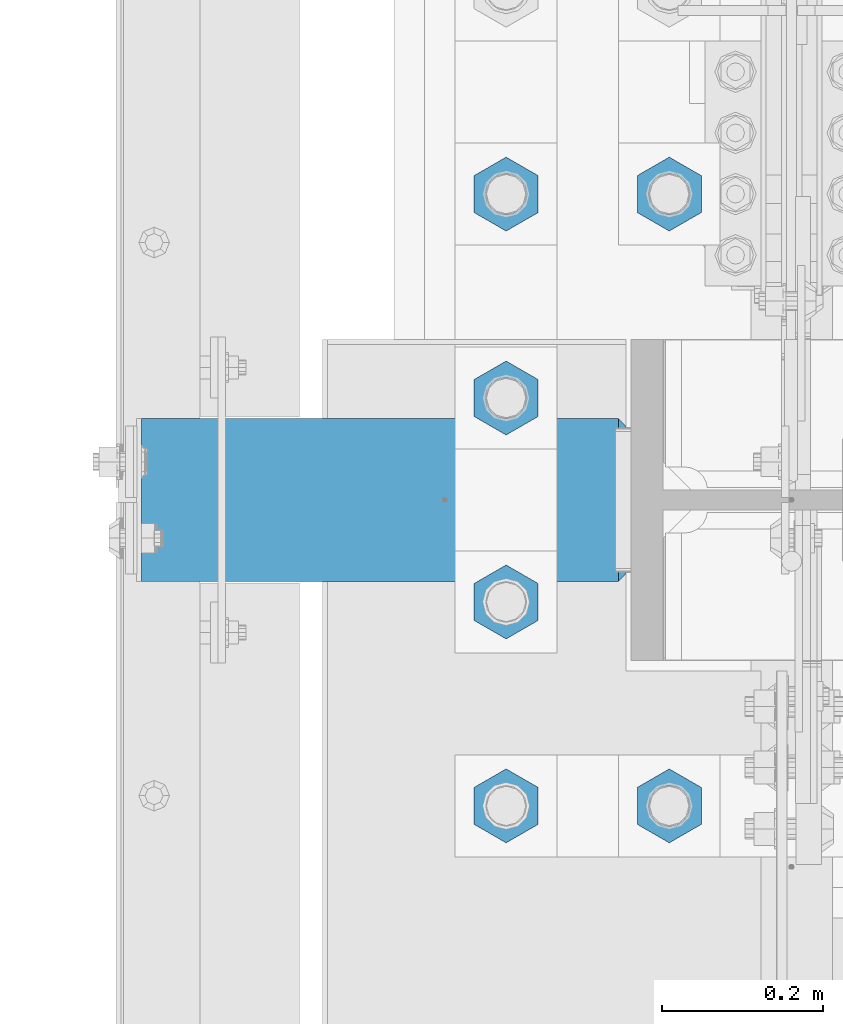
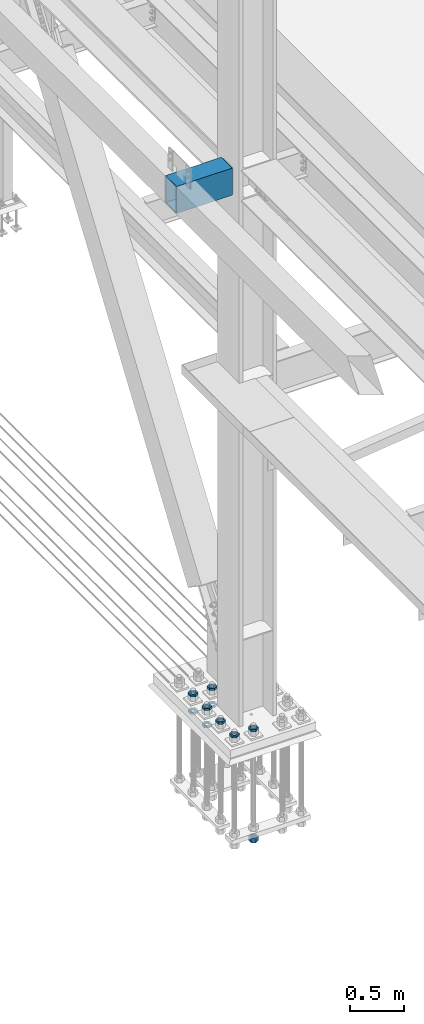
# One storey, part 2365 of 3843: 11 beams, 2 elements without a shape of their own.
"""IFC2X3 building model written with IfcOpenShell, lengths in millimetres."""

from ifc_helpers import new_model, si_unit, frame, origin_with_axes, place, context, subcontext, project, spatial, faceted_brep, material, type_object, element, aggregate, save


model = new_model("IFC2X3")

# Units and contexts
model_context = context("Model", 3, precision=1e-05, world=origin_with_axes())
body_context = subcontext(model_context, "Body", "Model", "MODEL_VIEW")
ifc_project = project(units=[si_unit("LENGTHUNIT", "METRE", prefix="MILLI"), si_unit("AREAUNIT", "SQUARE_METRE"), si_unit("VOLUMEUNIT", "CUBIC_METRE"), si_unit("MASSUNIT", "GRAM", prefix="KILO"), si_unit("TIMEUNIT", "SECOND"), si_unit("PLANEANGLEUNIT", "RADIAN"), si_unit("SOLIDANGLEUNIT", "STERADIAN"), si_unit("THERMODYNAMICTEMPERATUREUNIT", "DEGREE_CELSIUS"), si_unit("LUMINOUSINTENSITYUNIT", "LUMEN")], contexts=[model_context])

# Site, building, storey
site_placement = place(None, origin_with_axes())
site = spatial("IfcSite", under=ifc_project, at=site_placement, CompositionType="ELEMENT")
building_placement = place(site_placement, origin_with_axes())
building = spatial("IfcBuilding", under=site, at=building_placement, Name="Undefined", CompositionType="ELEMENT")
storey_placement = place(building_placement, origin_with_axes())
storey = spatial("IfcBuildingStorey", under=building, at=storey_placement, Name="Undefined", CompositionType="ELEMENT", Elevation=0.0)

# Assembly, beams
assembly_1_placement = place(storey_placement, origin_with_axes())
assembly_1 = element("IfcElementAssembly", 1, at=assembly_1_placement, inside=storey, Name="TEMPLATE", AssemblyPlace="NOTDEFINED", PredefinedType="RIGID_FRAME")
ifc_material_1 = material(Name="STEEL/A572-50")
beam_type_1 = type_object("IfcBeamType", Name="2_HALF_NUT", PredefinedType="NOTDEFINED")
beam_1_placement = place(assembly_1_placement, frame((36220.4, 67398.9, 30060.9), z_axis=(-1.0, 0.0, 0.0), x_axis=(0.0, 0.0, -1.0)))
beam_1 = element("IfcBeam", 2, at=beam_1_placement, type_object=beam_type_1, material=ifc_material_1, Name="NUT", ObjectType="2_HALF_NUT", context=body_context, shape_type="Brep", body=[
    faceted_brep([(0.0, -46.0369987487793, 0.0), (0.0, -23.0184993743896, -39.869213104248), (25.4000000000015, -23.0184993743896, -39.869213104248), (25.4000000000015, -46.0369987487793, 0.0), (0.0, 23.0184993743896, -39.869213104248), (25.4000000000015, 23.0184993743896, -39.869213104248), (0.0, 46.0369987487793, 0.0), (25.4000000000015, 46.0369987487793, 0.0), (0.0, 23.0184993743896, 39.869213104248), (25.4000000000015, 23.0184993743896, 39.869213104248), (0.0, -23.0184993743896, 39.869213104248), (25.4000000000015, -23.0184993743896, 39.869213104248), (0.0, 0.0, 26.1940002441406), (0.0, 11.3650617044477, 23.5999013092805), (25.4000000000015, 11.3650617044477, 23.5999013092805), (25.4000000000015, 0.0, 26.1940002441406), (0.0, 20.4791109456419, 16.3316083006721), (25.4000000000015, 20.4791109456419, 16.3316083006721), (0.0, 25.5370200498292, 5.82867859874386), (25.4000000000015, 25.5370200498292, 5.82867859874386), (0.0, 25.5370200498292, -5.82867859874386), (25.4000000000015, 25.5370200498292, -5.82867859874386), (0.0, 20.4791109456419, -16.3316083006721), (25.4000000000015, 20.4791109456419, -16.3316083006721), (0.0, 11.3650617044477, -23.5999013092805), (25.4000000000015, 11.3650617044477, -23.5999013092805), (0.0, 0.0, -26.1940002441406), (25.4000000000015, 0.0, -26.1940002441406), (0.0, -11.3650617044477, -23.5999013092805), (25.4000000000015, -11.3650617044477, -23.5999013092805), (0.0, -20.4791109456419, -16.3316083006721), (25.4000000000015, -20.4791109456419, -16.3316083006721), (0.0, -25.5370200498292, -5.82867859874386), (25.4000000000015, -25.5370200498292, -5.82867859874386), (0.0, -25.5370200498292, 5.82867859874386), (25.4000000000015, -25.5370200498292, 5.82867859874386), (0.0, -20.4791109456419, 16.3316083006721), (25.4000000000015, -20.4791109456419, 16.3316083006721), (0.0, -11.3650617044477, 23.5999013092805), (25.4000000000015, -11.3650617044477, 23.5999013092805)], [[[0, 1, 2, 3]], [[1, 4, 5, 2]], [[4, 6, 7, 5]], [[6, 8, 9, 7]], [[8, 10, 11, 9]], [[10, 0, 3, 11]], [[12, 13, 14, 15]], [[13, 16, 17, 14]], [[16, 18, 19, 17]], [[18, 20, 21, 19]], [[20, 22, 23, 21]], [[22, 24, 25, 23]], [[24, 26, 27, 25]], [[26, 28, 29, 27]], [[28, 30, 31, 29]], [[30, 32, 33, 31]], [[32, 34, 35, 33]], [[34, 36, 37, 35]], [[36, 38, 39, 37]], [[38, 12, 15, 39]], [[5, 7, 9, 11, 3, 2], [17, 19, 21, 23, 25, 27, 29, 31, 33, 35, 37, 39, 15, 14]], [[10, 8, 6, 4, 1, 0], [38, 36, 34, 32, 30, 28, 26, 24, 22, 20, 18, 16, 13, 12]]]),
])
beam_2_placement = place(assembly_1_placement, frame((36423.6, 67652.9, 30060.9), z_axis=(1.0, 0.0, 0.0), x_axis=(0.0, 0.0, -1.0)))
beam_2 = element("IfcBeam", 3, at=beam_2_placement, type_object=beam_type_1, material=ifc_material_1, Name="NUT", ObjectType="2_HALF_NUT", context=body_context, shape_type="Brep", body=[
    faceted_brep([(0.0, -46.0369987487793, 0.0), (0.0, -23.0184993743896, -39.869213104248), (25.4000000000015, -23.0184993743896, -39.869213104248), (25.4000000000015, -46.0369987487793, 0.0), (0.0, 23.0184993743896, -39.869213104248), (25.4000000000015, 23.0184993743896, -39.869213104248), (0.0, 46.0369987487793, 0.0), (25.4000000000015, 46.0369987487793, 0.0), (0.0, 23.0184993743896, 39.869213104248), (25.4000000000015, 23.0184993743896, 39.869213104248), (0.0, -23.0184993743896, 39.869213104248), (25.4000000000015, -23.0184993743896, 39.869213104248), (0.0, 0.0, 26.1940002441406), (0.0, 11.3650617044477, 23.5999013092805), (25.4000000000015, 11.3650617044477, 23.5999013092805), (25.4000000000015, 0.0, 26.1940002441406), (0.0, 20.4791109456419, 16.3316083006721), (25.4000000000015, 20.4791109456419, 16.3316083006721), (0.0, 25.5370200498292, 5.82867859874386), (25.4000000000015, 25.5370200498292, 5.82867859874386), (0.0, 25.5370200498292, -5.82867859874386), (25.4000000000015, 25.5370200498292, -5.82867859874386), (0.0, 20.4791109456419, -16.3316083006721), (25.4000000000015, 20.4791109456419, -16.3316083006721), (0.0, 11.3650617044477, -23.5999013092805), (25.4000000000015, 11.3650617044477, -23.5999013092805), (0.0, 0.0, -26.1940002441406), (25.4000000000015, 0.0, -26.1940002441406), (0.0, -11.3650617044477, -23.5999013092805), (25.4000000000015, -11.3650617044477, -23.5999013092805), (0.0, -20.4791109456419, -16.3316083006721), (25.4000000000015, -20.4791109456419, -16.3316083006721), (0.0, -25.5370200498292, -5.82867859874386), (25.4000000000015, -25.5370200498292, -5.82867859874386), (0.0, -25.5370200498292, 5.82867859874386), (25.4000000000015, -25.5370200498292, 5.82867859874386), (0.0, -20.4791109456419, 16.3316083006721), (25.4000000000015, -20.4791109456419, 16.3316083006721), (0.0, -11.3650617044477, 23.5999013092805), (25.4000000000015, -11.3650617044477, 23.5999013092805)], [[[0, 1, 2, 3]], [[1, 4, 5, 2]], [[4, 6, 7, 5]], [[6, 8, 9, 7]], [[8, 10, 11, 9]], [[10, 0, 3, 11]], [[12, 13, 14, 15]], [[13, 16, 17, 14]], [[16, 18, 19, 17]], [[18, 20, 21, 19]], [[20, 22, 23, 21]], [[22, 24, 25, 23]], [[24, 26, 27, 25]], [[26, 28, 29, 27]], [[28, 30, 31, 29]], [[30, 32, 33, 31]], [[32, 34, 35, 33]], [[34, 36, 37, 35]], [[36, 38, 39, 37]], [[38, 12, 15, 39]], [[5, 7, 9, 11, 3, 2], [17, 19, 21, 23, 25, 27, 29, 31, 33, 35, 37, 39, 15, 14]], [[10, 8, 6, 4, 1, 0], [38, 36, 34, 32, 30, 28, 26, 24, 22, 20, 18, 16, 13, 12]]]),
])
beam_3_placement = place(assembly_1_placement, frame((36220.4, 67652.9, 30060.9), z_axis=(1.0, 0.0, 0.0), x_axis=(0.0, 0.0, -1.0)))
beam_3 = element("IfcBeam", 4, at=beam_3_placement, type_object=beam_type_1, material=ifc_material_1, Name="NUT", ObjectType="2_HALF_NUT", context=body_context, shape_type="Brep", body=[
    faceted_brep([(0.0, -46.0369987487793, 0.0), (0.0, -23.0184993743896, -39.869213104248), (25.4000000000015, -23.0184993743896, -39.869213104248), (25.4000000000015, -46.0369987487793, 0.0), (0.0, 23.0184993743896, -39.869213104248), (25.4000000000015, 23.0184993743896, -39.869213104248), (0.0, 46.0369987487793, 0.0), (25.4000000000015, 46.0369987487793, 0.0), (0.0, 23.0184993743896, 39.869213104248), (25.4000000000015, 23.0184993743896, 39.869213104248), (0.0, -23.0184993743896, 39.869213104248), (25.4000000000015, -23.0184993743896, 39.869213104248), (0.0, 0.0, 26.1940002441406), (0.0, 11.3650617044477, 23.5999013092805), (25.4000000000015, 11.3650617044477, 23.5999013092805), (25.4000000000015, 0.0, 26.1940002441406), (0.0, 20.4791109456419, 16.3316083006721), (25.4000000000015, 20.4791109456419, 16.3316083006721), (0.0, 25.5370200498292, 5.82867859874386), (25.4000000000015, 25.5370200498292, 5.82867859874386), (0.0, 25.5370200498292, -5.82867859874386), (25.4000000000015, 25.5370200498292, -5.82867859874386), (0.0, 20.4791109456419, -16.3316083006721), (25.4000000000015, 20.4791109456419, -16.3316083006721), (0.0, 11.3650617044477, -23.5999013092805), (25.4000000000015, 11.3650617044477, -23.5999013092805), (0.0, 0.0, -26.1940002441406), (25.4000000000015, 0.0, -26.1940002441406), (0.0, -11.3650617044477, -23.5999013092805), (25.4000000000015, -11.3650617044477, -23.5999013092805), (0.0, -20.4791109456419, -16.3316083006721), (25.4000000000015, -20.4791109456419, -16.3316083006721), (0.0, -25.5370200498292, -5.82867859874386), (25.4000000000015, -25.5370200498292, -5.82867859874386), (0.0, -25.5370200498292, 5.82867859874386), (25.4000000000015, -25.5370200498292, 5.82867859874386), (0.0, -20.4791109456419, 16.3316083006721), (25.4000000000015, -20.4791109456419, 16.3316083006721), (0.0, -11.3650617044477, 23.5999013092805), (25.4000000000015, -11.3650617044477, 23.5999013092805)], [[[0, 1, 2, 3]], [[1, 4, 5, 2]], [[4, 6, 7, 5]], [[6, 8, 9, 7]], [[8, 10, 11, 9]], [[10, 0, 3, 11]], [[12, 13, 14, 15]], [[13, 16, 17, 14]], [[16, 18, 19, 17]], [[18, 20, 21, 19]], [[20, 22, 23, 21]], [[22, 24, 25, 23]], [[24, 26, 27, 25]], [[26, 28, 29, 27]], [[28, 30, 31, 29]], [[30, 32, 33, 31]], [[32, 34, 35, 33]], [[34, 36, 37, 35]], [[36, 38, 39, 37]], [[38, 12, 15, 39]], [[5, 7, 9, 11, 3, 2], [17, 19, 21, 23, 25, 27, 29, 31, 33, 35, 37, 39, 15, 14]], [[10, 8, 6, 4, 1, 0], [38, 36, 34, 32, 30, 28, 26, 24, 22, 20, 18, 16, 13, 12]]]),
])
beam_4_placement = place(assembly_1_placement, frame((36423.6, 67652.9, 30257.75), z_axis=(-1.0, 0.0, 0.0), x_axis=(0.0, 0.0, -1.0)))
beam_4 = element("IfcBeam", 5, at=beam_4_placement, type_object=beam_type_1, material=ifc_material_1, Name="NUT", ObjectType="2_HALF_NUT", context=body_context, shape_type="Brep", body=[
    faceted_brep([(0.0, -46.0369987487793, 0.0), (0.0, -23.0184993743896, -39.869213104248), (25.4000000000015, -23.0184993743896, -39.869213104248), (25.4000000000015, -46.0369987487793, 0.0), (0.0, 23.0184993743896, -39.869213104248), (25.4000000000015, 23.0184993743896, -39.869213104248), (0.0, 46.0369987487793, 0.0), (25.4000000000015, 46.0369987487793, 0.0), (0.0, 23.0184993743896, 39.869213104248), (25.4000000000015, 23.0184993743896, 39.869213104248), (0.0, -23.0184993743896, 39.869213104248), (25.4000000000015, -23.0184993743896, 39.869213104248), (0.0, 0.0, 26.1940002441406), (0.0, 11.3650617044477, 23.5999013092805), (25.4000000000015, 11.3650617044477, 23.5999013092805), (25.4000000000015, 0.0, 26.1940002441406), (0.0, 20.4791109456419, 16.3316083006721), (25.4000000000015, 20.4791109456419, 16.3316083006721), (0.0, 25.5370200498292, 5.82867859874386), (25.4000000000015, 25.5370200498292, 5.82867859874386), (0.0, 25.5370200498292, -5.82867859874386), (25.4000000000015, 25.5370200498292, -5.82867859874386), (0.0, 20.4791109456419, -16.3316083006721), (25.4000000000015, 20.4791109456419, -16.3316083006721), (0.0, 11.3650617044477, -23.5999013092805), (25.4000000000015, 11.3650617044477, -23.5999013092805), (0.0, 0.0, -26.1940002441406), (25.4000000000015, 0.0, -26.1940002441406), (0.0, -11.3650617044477, -23.5999013092805), (25.4000000000015, -11.3650617044477, -23.5999013092805), (0.0, -20.4791109456419, -16.3316083006721), (25.4000000000015, -20.4791109456419, -16.3316083006721), (0.0, -25.5370200498292, -5.82867859874386), (25.4000000000015, -25.5370200498292, -5.82867859874386), (0.0, -25.5370200498292, 5.82867859874386), (25.4000000000015, -25.5370200498292, 5.82867859874386), (0.0, -20.4791109456419, 16.3316083006721), (25.4000000000015, -20.4791109456419, 16.3316083006721), (0.0, -11.3650617044477, 23.5999013092805), (25.4000000000015, -11.3650617044477, 23.5999013092805)], [[[0, 1, 2, 3]], [[1, 4, 5, 2]], [[4, 6, 7, 5]], [[6, 8, 9, 7]], [[8, 10, 11, 9]], [[10, 0, 3, 11]], [[12, 13, 14, 15]], [[13, 16, 17, 14]], [[16, 18, 19, 17]], [[18, 20, 21, 19]], [[20, 22, 23, 21]], [[22, 24, 25, 23]], [[24, 26, 27, 25]], [[26, 28, 29, 27]], [[28, 30, 31, 29]], [[30, 32, 33, 31]], [[32, 34, 35, 33]], [[34, 36, 37, 35]], [[36, 38, 39, 37]], [[38, 12, 15, 39]], [[5, 7, 9, 11, 3, 2], [17, 19, 21, 23, 25, 27, 29, 31, 33, 35, 37, 39, 15, 14]], [[10, 8, 6, 4, 1, 0], [38, 36, 34, 32, 30, 28, 26, 24, 22, 20, 18, 16, 13, 12]]]),
])
beam_5_placement = place(assembly_1_placement, frame((36220.4, 67652.9, 30257.75), z_axis=(-1.0, 0.0, 0.0), x_axis=(0.0, 0.0, -1.0)))
beam_5 = element("IfcBeam", 6, at=beam_5_placement, type_object=beam_type_1, material=ifc_material_1, Name="NUT", ObjectType="2_HALF_NUT", context=body_context, shape_type="Brep", body=[
    faceted_brep([(0.0, -46.0369987487793, 0.0), (0.0, -23.0184993743896, -39.869213104248), (25.4000000000015, -23.0184993743896, -39.869213104248), (25.4000000000015, -46.0369987487793, 0.0), (0.0, 23.0184993743896, -39.869213104248), (25.4000000000015, 23.0184993743896, -39.869213104248), (0.0, 46.0369987487793, 0.0), (25.4000000000015, 46.0369987487793, 0.0), (0.0, 23.0184993743896, 39.869213104248), (25.4000000000015, 23.0184993743896, 39.869213104248), (0.0, -23.0184993743896, 39.869213104248), (25.4000000000015, -23.0184993743896, 39.869213104248), (0.0, 0.0, 26.1940002441406), (0.0, 11.3650617044477, 23.5999013092805), (25.4000000000015, 11.3650617044477, 23.5999013092805), (25.4000000000015, 0.0, 26.1940002441406), (0.0, 20.4791109456419, 16.3316083006721), (25.4000000000015, 20.4791109456419, 16.3316083006721), (0.0, 25.5370200498292, 5.82867859874386), (25.4000000000015, 25.5370200498292, 5.82867859874386), (0.0, 25.5370200498292, -5.82867859874386), (25.4000000000015, 25.5370200498292, -5.82867859874386), (0.0, 20.4791109456419, -16.3316083006721), (25.4000000000015, 20.4791109456419, -16.3316083006721), (0.0, 11.3650617044477, -23.5999013092805), (25.4000000000015, 11.3650617044477, -23.5999013092805), (0.0, 0.0, -26.1940002441406), (25.4000000000015, 0.0, -26.1940002441406), (0.0, -11.3650617044477, -23.5999013092805), (25.4000000000015, -11.3650617044477, -23.5999013092805), (0.0, -20.4791109456419, -16.3316083006721), (25.4000000000015, -20.4791109456419, -16.3316083006721), (0.0, -25.5370200498292, -5.82867859874386), (25.4000000000015, -25.5370200498292, -5.82867859874386), (0.0, -25.5370200498292, 5.82867859874386), (25.4000000000015, -25.5370200498292, 5.82867859874386), (0.0, -20.4791109456419, 16.3316083006721), (25.4000000000015, -20.4791109456419, 16.3316083006721), (0.0, -11.3650617044477, 23.5999013092805), (25.4000000000015, -11.3650617044477, 23.5999013092805)], [[[0, 1, 2, 3]], [[1, 4, 5, 2]], [[4, 6, 7, 5]], [[6, 8, 9, 7]], [[8, 10, 11, 9]], [[10, 0, 3, 11]], [[12, 13, 14, 15]], [[13, 16, 17, 14]], [[16, 18, 19, 17]], [[18, 20, 21, 19]], [[20, 22, 23, 21]], [[22, 24, 25, 23]], [[24, 26, 27, 25]], [[26, 28, 29, 27]], [[28, 30, 31, 29]], [[30, 32, 33, 31]], [[32, 34, 35, 33]], [[34, 36, 37, 35]], [[36, 38, 39, 37]], [[38, 12, 15, 39]], [[5, 7, 9, 11, 3, 2], [17, 19, 21, 23, 25, 27, 29, 31, 33, 35, 37, 39, 15, 14]], [[10, 8, 6, 4, 1, 0], [38, 36, 34, 32, 30, 28, 26, 24, 22, 20, 18, 16, 13, 12]]]),
])
beam_6_placement = place(assembly_1_placement, frame((36220.4, 67398.9, 30257.75), z_axis=(1.0, 0.0, 0.0), x_axis=(0.0, 0.0, -1.0)))
beam_6 = element("IfcBeam", 7, at=beam_6_placement, type_object=beam_type_1, material=ifc_material_1, Name="NUT", ObjectType="2_HALF_NUT", context=body_context, shape_type="Brep", body=[
    faceted_brep([(0.0, -46.0369987487793, 0.0), (0.0, -23.0184993743896, -39.869213104248), (25.4000000000015, -23.0184993743896, -39.869213104248), (25.4000000000015, -46.0369987487793, 0.0), (0.0, 23.0184993743896, -39.869213104248), (25.4000000000015, 23.0184993743896, -39.869213104248), (0.0, 46.0369987487793, 0.0), (25.4000000000015, 46.0369987487793, 0.0), (0.0, 23.0184993743896, 39.869213104248), (25.4000000000015, 23.0184993743896, 39.869213104248), (0.0, -23.0184993743896, 39.869213104248), (25.4000000000015, -23.0184993743896, 39.869213104248), (0.0, 0.0, 26.1940002441406), (0.0, 11.3650617044477, 23.5999013092805), (25.4000000000015, 11.3650617044477, 23.5999013092805), (25.4000000000015, 0.0, 26.1940002441406), (0.0, 20.4791109456419, 16.3316083006721), (25.4000000000015, 20.4791109456419, 16.3316083006721), (0.0, 25.5370200498292, 5.82867859874386), (25.4000000000015, 25.5370200498292, 5.82867859874386), (0.0, 25.5370200498292, -5.82867859874386), (25.4000000000015, 25.5370200498292, -5.82867859874386), (0.0, 20.4791109456419, -16.3316083006721), (25.4000000000015, 20.4791109456419, -16.3316083006721), (0.0, 11.3650617044477, -23.5999013092805), (25.4000000000015, 11.3650617044477, -23.5999013092805), (0.0, 0.0, -26.1940002441406), (25.4000000000015, 0.0, -26.1940002441406), (0.0, -11.3650617044477, -23.5999013092805), (25.4000000000015, -11.3650617044477, -23.5999013092805), (0.0, -20.4791109456419, -16.3316083006721), (25.4000000000015, -20.4791109456419, -16.3316083006721), (0.0, -25.5370200498292, -5.82867859874386), (25.4000000000015, -25.5370200498292, -5.82867859874386), (0.0, -25.5370200498292, 5.82867859874386), (25.4000000000015, -25.5370200498292, 5.82867859874386), (0.0, -20.4791109456419, 16.3316083006721), (25.4000000000015, -20.4791109456419, 16.3316083006721), (0.0, -11.3650617044477, 23.5999013092805), (25.4000000000015, -11.3650617044477, 23.5999013092805)], [[[0, 1, 2, 3]], [[1, 4, 5, 2]], [[4, 6, 7, 5]], [[6, 8, 9, 7]], [[8, 10, 11, 9]], [[10, 0, 3, 11]], [[12, 13, 14, 15]], [[13, 16, 17, 14]], [[16, 18, 19, 17]], [[18, 20, 21, 19]], [[20, 22, 23, 21]], [[22, 24, 25, 23]], [[24, 26, 27, 25]], [[26, 28, 29, 27]], [[28, 30, 31, 29]], [[30, 32, 33, 31]], [[32, 34, 35, 33]], [[34, 36, 37, 35]], [[36, 38, 39, 37]], [[38, 12, 15, 39]], [[5, 7, 9, 11, 3, 2], [17, 19, 21, 23, 25, 27, 29, 31, 33, 35, 37, 39, 15, 14]], [[10, 8, 6, 4, 1, 0], [38, 36, 34, 32, 30, 28, 26, 24, 22, 20, 18, 16, 13, 12]]]),
])
beam_7_placement = place(assembly_1_placement, frame((36220.4, 67144.9, 30257.75), z_axis=(1.0, 0.0, 0.0), x_axis=(0.0, 0.0, -1.0)))
beam_7 = element("IfcBeam", 8, at=beam_7_placement, type_object=beam_type_1, material=ifc_material_1, Name="NUT", ObjectType="2_HALF_NUT", context=body_context, shape_type="Brep", body=[
    faceted_brep([(0.0, -46.0369987487793, 0.0), (0.0, -23.0184993743896, -39.869213104248), (25.4000000000015, -23.0184993743896, -39.869213104248), (25.4000000000015, -46.0369987487793, 0.0), (0.0, 23.0184993743896, -39.869213104248), (25.4000000000015, 23.0184993743896, -39.869213104248), (0.0, 46.0369987487793, 0.0), (25.4000000000015, 46.0369987487793, 0.0), (0.0, 23.0184993743896, 39.869213104248), (25.4000000000015, 23.0184993743896, 39.869213104248), (0.0, -23.0184993743896, 39.869213104248), (25.4000000000015, -23.0184993743896, 39.869213104248), (0.0, 0.0, 26.1940002441406), (0.0, 11.3650617044477, 23.5999013092805), (25.4000000000015, 11.3650617044477, 23.5999013092805), (25.4000000000015, 0.0, 26.1940002441406), (0.0, 20.4791109456419, 16.3316083006721), (25.4000000000015, 20.4791109456419, 16.3316083006721), (0.0, 25.5370200498292, 5.82867859874386), (25.4000000000015, 25.5370200498292, 5.82867859874386), (0.0, 25.5370200498292, -5.82867859874386), (25.4000000000015, 25.5370200498292, -5.82867859874386), (0.0, 20.4791109456419, -16.3316083006721), (25.4000000000015, 20.4791109456419, -16.3316083006721), (0.0, 11.3650617044477, -23.5999013092805), (25.4000000000015, 11.3650617044477, -23.5999013092805), (0.0, 0.0, -26.1940002441406), (25.4000000000015, 0.0, -26.1940002441406), (0.0, -11.3650617044477, -23.5999013092805), (25.4000000000015, -11.3650617044477, -23.5999013092805), (0.0, -20.4791109456419, -16.3316083006721), (25.4000000000015, -20.4791109456419, -16.3316083006721), (0.0, -25.5370200498292, -5.82867859874386), (25.4000000000015, -25.5370200498292, -5.82867859874386), (0.0, -25.5370200498292, 5.82867859874386), (25.4000000000015, -25.5370200498292, 5.82867859874386), (0.0, -20.4791109456419, 16.3316083006721), (25.4000000000015, -20.4791109456419, 16.3316083006721), (0.0, -11.3650617044477, 23.5999013092805), (25.4000000000015, -11.3650617044477, 23.5999013092805)], [[[0, 1, 2, 3]], [[1, 4, 5, 2]], [[4, 6, 7, 5]], [[6, 8, 9, 7]], [[8, 10, 11, 9]], [[10, 0, 3, 11]], [[12, 13, 14, 15]], [[13, 16, 17, 14]], [[16, 18, 19, 17]], [[18, 20, 21, 19]], [[20, 22, 23, 21]], [[22, 24, 25, 23]], [[24, 26, 27, 25]], [[26, 28, 29, 27]], [[28, 30, 31, 29]], [[30, 32, 33, 31]], [[32, 34, 35, 33]], [[34, 36, 37, 35]], [[36, 38, 39, 37]], [[38, 12, 15, 39]], [[5, 7, 9, 11, 3, 2], [17, 19, 21, 23, 25, 27, 29, 31, 33, 35, 37, 39, 15, 14]], [[10, 8, 6, 4, 1, 0], [38, 36, 34, 32, 30, 28, 26, 24, 22, 20, 18, 16, 13, 12]]]),
])
beam_8_placement = place(assembly_1_placement, frame((36220.4, 66890.9, 30257.75), z_axis=(1.0, 0.0, 0.0), x_axis=(0.0, 0.0, -1.0)))
beam_8 = element("IfcBeam", 9, at=beam_8_placement, type_object=beam_type_1, material=ifc_material_1, Name="NUT", ObjectType="2_HALF_NUT", context=body_context, shape_type="Brep", body=[
    faceted_brep([(0.0, -46.0369987487793, 0.0), (0.0, -23.0184993743896, -39.869213104248), (25.4000000000015, -23.0184993743896, -39.869213104248), (25.4000000000015, -46.0369987487793, 0.0), (0.0, 23.0184993743896, -39.869213104248), (25.4000000000015, 23.0184993743896, -39.869213104248), (0.0, 46.0369987487793, 0.0), (25.4000000000015, 46.0369987487793, 0.0), (0.0, 23.0184993743896, 39.869213104248), (25.4000000000015, 23.0184993743896, 39.869213104248), (0.0, -23.0184993743896, 39.869213104248), (25.4000000000015, -23.0184993743896, 39.869213104248), (0.0, 0.0, 26.1940002441406), (0.0, 11.3650617044477, 23.5999013092805), (25.4000000000015, 11.3650617044477, 23.5999013092805), (25.4000000000015, 0.0, 26.1940002441406), (0.0, 20.4791109456419, 16.3316083006721), (25.4000000000015, 20.4791109456419, 16.3316083006721), (0.0, 25.5370200498292, 5.82867859874386), (25.4000000000015, 25.5370200498292, 5.82867859874386), (0.0, 25.5370200498292, -5.82867859874386), (25.4000000000015, 25.5370200498292, -5.82867859874386), (0.0, 20.4791109456419, -16.3316083006721), (25.4000000000015, 20.4791109456419, -16.3316083006721), (0.0, 11.3650617044477, -23.5999013092805), (25.4000000000015, 11.3650617044477, -23.5999013092805), (0.0, 0.0, -26.1940002441406), (25.4000000000015, 0.0, -26.1940002441406), (0.0, -11.3650617044477, -23.5999013092805), (25.4000000000015, -11.3650617044477, -23.5999013092805), (0.0, -20.4791109456419, -16.3316083006721), (25.4000000000015, -20.4791109456419, -16.3316083006721), (0.0, -25.5370200498292, -5.82867859874386), (25.4000000000015, -25.5370200498292, -5.82867859874386), (0.0, -25.5370200498292, 5.82867859874386), (25.4000000000015, -25.5370200498292, 5.82867859874386), (0.0, -20.4791109456419, 16.3316083006721), (25.4000000000015, -20.4791109456419, 16.3316083006721), (0.0, -11.3650617044477, 23.5999013092805), (25.4000000000015, -11.3650617044477, 23.5999013092805)], [[[0, 1, 2, 3]], [[1, 4, 5, 2]], [[4, 6, 7, 5]], [[6, 8, 9, 7]], [[8, 10, 11, 9]], [[10, 0, 3, 11]], [[12, 13, 14, 15]], [[13, 16, 17, 14]], [[16, 18, 19, 17]], [[18, 20, 21, 19]], [[20, 22, 23, 21]], [[22, 24, 25, 23]], [[24, 26, 27, 25]], [[26, 28, 29, 27]], [[28, 30, 31, 29]], [[30, 32, 33, 31]], [[32, 34, 35, 33]], [[34, 36, 37, 35]], [[36, 38, 39, 37]], [[38, 12, 15, 39]], [[5, 7, 9, 11, 3, 2], [17, 19, 21, 23, 25, 27, 29, 31, 33, 35, 37, 39, 15, 14]], [[10, 8, 6, 4, 1, 0], [38, 36, 34, 32, 30, 28, 26, 24, 22, 20, 18, 16, 13, 12]]]),
])
beam_9_placement = place(assembly_1_placement, frame((36423.6, 66890.9, 30257.75), z_axis=(1.0, 0.0, 0.0), x_axis=(0.0, 0.0, -1.0)))
beam_9 = element("IfcBeam", 10, at=beam_9_placement, type_object=beam_type_1, material=ifc_material_1, Name="NUT", ObjectType="2_HALF_NUT", context=body_context, shape_type="Brep", body=[
    faceted_brep([(0.0, -46.0369987487793, 0.0), (0.0, -23.0184993743896, -39.869213104248), (25.4000000000015, -23.0184993743896, -39.869213104248), (25.4000000000015, -46.0369987487793, 0.0), (0.0, 23.0184993743896, -39.869213104248), (25.4000000000015, 23.0184993743896, -39.869213104248), (0.0, 46.0369987487793, 0.0), (25.4000000000015, 46.0369987487793, 0.0), (0.0, 23.0184993743896, 39.869213104248), (25.4000000000015, 23.0184993743896, 39.869213104248), (0.0, -23.0184993743896, 39.869213104248), (25.4000000000015, -23.0184993743896, 39.869213104248), (0.0, 0.0, 26.1940002441406), (0.0, 11.3650617044477, 23.5999013092805), (25.4000000000015, 11.3650617044477, 23.5999013092805), (25.4000000000015, 0.0, 26.1940002441406), (0.0, 20.4791109456419, 16.3316083006721), (25.4000000000015, 20.4791109456419, 16.3316083006721), (0.0, 25.5370200498292, 5.82867859874386), (25.4000000000015, 25.5370200498292, 5.82867859874386), (0.0, 25.5370200498292, -5.82867859874386), (25.4000000000015, 25.5370200498292, -5.82867859874386), (0.0, 20.4791109456419, -16.3316083006721), (25.4000000000015, 20.4791109456419, -16.3316083006721), (0.0, 11.3650617044477, -23.5999013092805), (25.4000000000015, 11.3650617044477, -23.5999013092805), (0.0, 0.0, -26.1940002441406), (25.4000000000015, 0.0, -26.1940002441406), (0.0, -11.3650617044477, -23.5999013092805), (25.4000000000015, -11.3650617044477, -23.5999013092805), (0.0, -20.4791109456419, -16.3316083006721), (25.4000000000015, -20.4791109456419, -16.3316083006721), (0.0, -25.5370200498292, -5.82867859874386), (25.4000000000015, -25.5370200498292, -5.82867859874386), (0.0, -25.5370200498292, 5.82867859874386), (25.4000000000015, -25.5370200498292, 5.82867859874386), (0.0, -20.4791109456419, 16.3316083006721), (25.4000000000015, -20.4791109456419, 16.3316083006721), (0.0, -11.3650617044477, 23.5999013092805), (25.4000000000015, -11.3650617044477, 23.5999013092805)], [[[0, 1, 2, 3]], [[1, 4, 5, 2]], [[4, 6, 7, 5]], [[6, 8, 9, 7]], [[8, 10, 11, 9]], [[10, 0, 3, 11]], [[12, 13, 14, 15]], [[13, 16, 17, 14]], [[16, 18, 19, 17]], [[18, 20, 21, 19]], [[20, 22, 23, 21]], [[22, 24, 25, 23]], [[24, 26, 27, 25]], [[26, 28, 29, 27]], [[28, 30, 31, 29]], [[30, 32, 33, 31]], [[32, 34, 35, 33]], [[34, 36, 37, 35]], [[36, 38, 39, 37]], [[38, 12, 15, 39]], [[5, 7, 9, 11, 3, 2], [17, 19, 21, 23, 25, 27, 29, 31, 33, 35, 37, 39, 15, 14]], [[10, 8, 6, 4, 1, 0], [38, 36, 34, 32, 30, 28, 26, 24, 22, 20, 18, 16, 13, 12]]]),
])
beam_type_2 = type_object("IfcBeamType", Name="2_HEAVY_HEX_NUT", PredefinedType="NOTDEFINED")
beam_10_placement = place(assembly_1_placement, frame((36423.6, 66890.9, 29032.2), z_axis=(1.0, 0.0, 0.0), x_axis=(0.0, 0.0, -1.0)))
beam_10 = element("IfcBeam", 11, at=beam_10_placement, type_object=beam_type_2, material=ifc_material_1, Name="NUT", ObjectType="2_HEAVY_HEX_NUT", context=body_context, shape_type="Brep", body=[
    faceted_brep([(0.0, -46.0369987487793, 0.0), (0.0, -23.0184993743896, -39.869213104248), (50.7999999999993, -23.0184993743896, -39.869213104248), (50.7999999999993, -46.0369987487793, 0.0), (0.0, 23.0184993743896, -39.869213104248), (50.7999999999993, 23.0184993743896, -39.869213104248), (0.0, 46.0369987487793, 0.0), (50.7999999999993, 46.0369987487793, 0.0), (0.0, 23.0184993743896, 39.869213104248), (50.7999999999993, 23.0184993743896, 39.869213104248), (0.0, -23.0184993743896, 39.869213104248), (50.7999999999993, -23.0184993743896, 39.869213104248), (0.0, 0.0, 26.1940002441406), (0.0, 11.3650617044477, 23.5999013092805), (50.7999999999993, 11.3650617044477, 23.5999013092805), (50.7999999999993, 0.0, 26.1940002441406), (0.0, 20.4791109456419, 16.3316083006721), (50.7999999999993, 20.4791109456419, 16.3316083006721), (0.0, 25.5370200498292, 5.82867859874386), (50.7999999999993, 25.5370200498292, 5.82867859874386), (0.0, 25.5370200498292, -5.82867859874386), (50.7999999999993, 25.5370200498292, -5.82867859874386), (0.0, 20.4791109456419, -16.3316083006721), (50.7999999999993, 20.4791109456419, -16.3316083006721), (0.0, 11.3650617044477, -23.5999013092805), (50.7999999999993, 11.3650617044477, -23.5999013092805), (0.0, 0.0, -26.1940002441406), (50.7999999999993, 0.0, -26.1940002441406), (0.0, -11.3650617044477, -23.5999013092805), (50.7999999999993, -11.3650617044477, -23.5999013092805), (0.0, -20.4791109456419, -16.3316083006721), (50.7999999999993, -20.4791109456419, -16.3316083006721), (0.0, -25.5370200498292, -5.82867859874386), (50.7999999999993, -25.5370200498292, -5.82867859874386), (0.0, -25.5370200498292, 5.82867859874386), (50.7999999999993, -25.5370200498292, 5.82867859874386), (0.0, -20.4791109456419, 16.3316083006721), (50.7999999999993, -20.4791109456419, 16.3316083006721), (0.0, -11.3650617044477, 23.5999013092805), (50.7999999999993, -11.3650617044477, 23.5999013092805)], [[[0, 1, 2, 3]], [[1, 4, 5, 2]], [[4, 6, 7, 5]], [[6, 8, 9, 7]], [[8, 10, 11, 9]], [[10, 0, 3, 11]], [[12, 13, 14, 15]], [[13, 16, 17, 14]], [[16, 18, 19, 17]], [[18, 20, 21, 19]], [[20, 22, 23, 21]], [[22, 24, 25, 23]], [[24, 26, 27, 25]], [[26, 28, 29, 27]], [[28, 30, 31, 29]], [[30, 32, 33, 31]], [[32, 34, 35, 33]], [[34, 36, 37, 35]], [[36, 38, 39, 37]], [[38, 12, 15, 39]], [[5, 7, 9, 11, 3, 2], [17, 19, 21, 23, 25, 27, 29, 31, 33, 35, 37, 39, 15, 14]], [[10, 8, 6, 4, 1, 0], [38, 36, 34, 32, 30, 28, 26, 24, 22, 20, 18, 16, 13, 12]]]),
])
aggregate(assembly_1, [beam_1, beam_2, beam_3, beam_4, beam_5, beam_6, beam_7, beam_8, beam_9, beam_10])

# Assembly, beam
assembly_2_placement = place(storey_placement, origin_with_axes())
assembly_2 = element("IfcElementAssembly", 12, at=assembly_2_placement, inside=storey, Name="COLUMN", AssemblyPlace="NOTDEFINED", PredefinedType="RIGID_FRAME")
ifc_material_2 = material()
beam_type_3 = type_object("IfcBeamType", Name="HSS12X8X3/8", PredefinedType="NOTDEFINED")
beam_11_placement = place(assembly_2_placement, frame((35760.025, 67271.9, 36252.15), z_axis=(0.0, 0.0, 1.0), x_axis=(1.0, 0.0, 0.0)))
beam_11 = element("IfcBeam", 13, at=beam_11_placement, type_object=beam_type_3, material=ifc_material_2, Name="BEAM", ObjectType="HSS12X8X3/8", context=body_context, shape_type="Brep", body=[
    faceted_brep([(609.600000000006, 92.0749999999971, 142.875), (609.600000000006, 92.0749999999971, -142.875), (600.075000000004, 101.600000000006, -152.400000000001), (600.075000000004, 101.600000000006, 152.400000000001), (609.600000000006, -92.0749999999971, -142.875), (600.075000000004, -101.600000000006, -152.400000000001), (609.600000000006, -92.0749999999971, 142.875), (600.075000000004, -101.600000000006, 152.400000000001), (6.35000000002037, 92.0749999999971, 142.875), (6.35000000002037, 92.0749999999971, -142.875), (6.35000000002037, -92.0749999999971, 142.875), (6.35000000002037, -92.0749999999971, -142.875), (6.35000000002037, -101.600000000006, -152.400000000001), (6.35000000002037, -101.600000000006, 152.400000000001), (6.35000000002037, 101.600000000006, 152.400000000001), (6.35000000002037, 101.600000000006, -152.400000000001)], [[[0, 1, 2, 3]], [[4, 5, 2, 1]], [[6, 7, 5, 4]], [[8, 9, 1, 0]], [[10, 8, 0, 6]], [[11, 10, 6, 4]], [[9, 11, 4, 1]], [[12, 13, 14, 15], [8, 10, 11, 9]], [[15, 14, 3, 2]], [[12, 15, 2, 5]], [[13, 12, 5, 7]], [[14, 13, 7, 3]], [[0, 3, 7, 6]]]),
])
aggregate(assembly_2, [beam_11])

save(model, "model.ifc")
